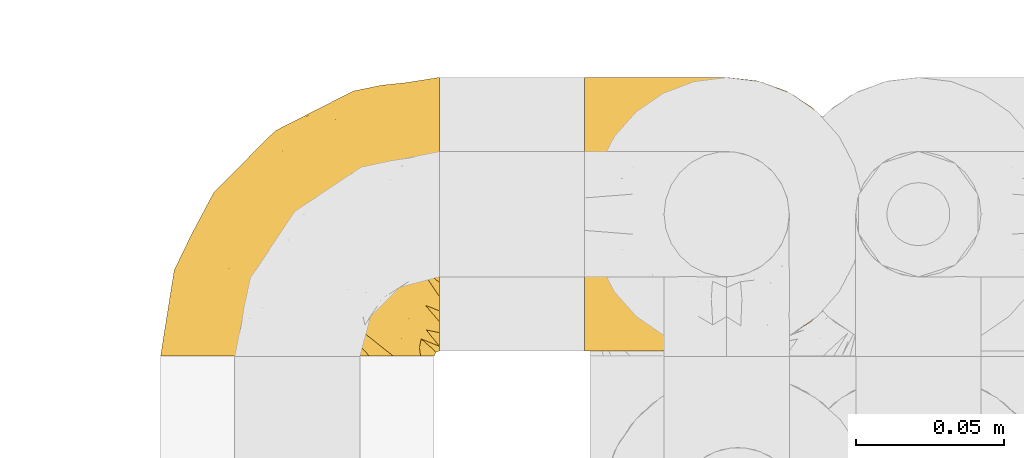
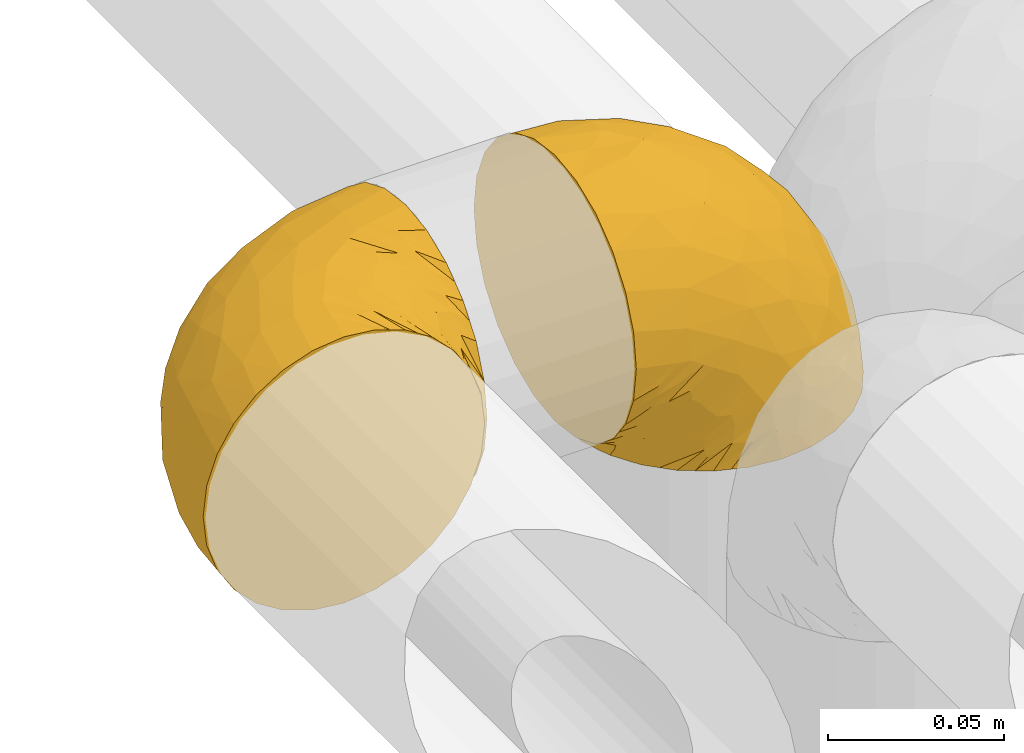
# One storey, part 239 of 827: 2 coverings.
"""IFC2X3 building model written with IfcOpenShell, lengths in millimetres."""

from ifc_helpers import new_model, entity, si_unit, converted_unit, derived_unit, direction, frame, origin, place, context, subcontext, project, spatial, faceted_brep, element, save


model = new_model("IFC2X3")

# Units and contexts
model_context = context("Model", 3, precision=0.01, world=origin(), true_north=direction((6.12303176911189e-17, 1.0)))
body_context = subcontext(model_context, "Body", "Model", "MODEL_VIEW")
ifc_project = project(units=[si_unit("LENGTHUNIT", "METRE", prefix="MILLI"), si_unit("AREAUNIT", "SQUARE_METRE"), si_unit("VOLUMEUNIT", "CUBIC_METRE"), converted_unit("PLANEANGLEUNIT", "DEGREE", entity("IfcRatioMeasure", 0.0174532925199433), si_unit("PLANEANGLEUNIT", "RADIAN"), dimensions=[0, 0, 0, 0, 0, 0, 0]), si_unit("MASSUNIT", "GRAM", prefix="KILO"), derived_unit("MASSDENSITYUNIT", [(si_unit("MASSUNIT", "GRAM", prefix="KILO"), 1), (si_unit("LENGTHUNIT", "METRE"), -3)]), derived_unit("MOMENTOFINERTIAUNIT", [(si_unit("LENGTHUNIT", "METRE"), 4)]), si_unit("TIMEUNIT", "SECOND"), si_unit("FREQUENCYUNIT", "HERTZ"), si_unit("THERMODYNAMICTEMPERATUREUNIT", "DEGREE_CELSIUS"), derived_unit("THERMALTRANSMITTANCEUNIT", [(si_unit("MASSUNIT", "GRAM", prefix="KILO"), 1), (si_unit("THERMODYNAMICTEMPERATUREUNIT", "KELVIN"), -1), (si_unit("TIMEUNIT", "SECOND"), -3)]), derived_unit("VOLUMETRICFLOWRATEUNIT", [(si_unit("LENGTHUNIT", "METRE"), 3), (si_unit("TIMEUNIT", "SECOND"), -1)]), derived_unit("MASSFLOWRATEUNIT", [(si_unit("MASSUNIT", "GRAM", prefix="KILO"), 1), (si_unit("TIMEUNIT", "SECOND"), -1)]), derived_unit("ROTATIONALFREQUENCYUNIT", [(si_unit("TIMEUNIT", "SECOND"), -1)]), si_unit("ELECTRICCURRENTUNIT", "AMPERE"), si_unit("ELECTRICVOLTAGEUNIT", "VOLT"), si_unit("POWERUNIT", "WATT"), si_unit("FORCEUNIT", "NEWTON", prefix="KILO"), si_unit("ILLUMINANCEUNIT", "LUX"), si_unit("LUMINOUSFLUXUNIT", "LUMEN"), si_unit("LUMINOUSINTENSITYUNIT", "CANDELA"), derived_unit("USERDEFINED", [(si_unit("MASSUNIT", "GRAM", prefix="KILO"), -1), (si_unit("LENGTHUNIT", "METRE"), -2), (si_unit("TIMEUNIT", "SECOND"), 3), (si_unit("LUMINOUSFLUXUNIT", "LUMEN"), 1)]), derived_unit("LINEARVELOCITYUNIT", [(si_unit("LENGTHUNIT", "METRE"), 1), (si_unit("TIMEUNIT", "SECOND"), -1)]), si_unit("PRESSUREUNIT", "PASCAL"), derived_unit("USERDEFINED", [(si_unit("LENGTHUNIT", "METRE"), -2), (si_unit("MASSUNIT", "GRAM", prefix="KILO"), 1), (si_unit("TIMEUNIT", "SECOND"), -2)]), derived_unit("LINEARFORCEUNIT", [(si_unit("MASSUNIT", "GRAM", prefix="KILO"), 1), (si_unit("LENGTHUNIT", "METRE"), 1), (si_unit("TIMEUNIT", "SECOND"), -2), (si_unit("LENGTHUNIT", "METRE"), -1)]), derived_unit("PLANARFORCEUNIT", [(si_unit("MASSUNIT", "GRAM", prefix="KILO"), 1), (si_unit("LENGTHUNIT", "METRE"), 1), (si_unit("TIMEUNIT", "SECOND"), -2), (si_unit("LENGTHUNIT", "METRE"), -2)])], contexts=[model_context])

# Site, building, storey
site_placement = place(None, origin())
site = spatial("IfcSite", under=ifc_project, at=site_placement, CompositionType="ELEMENT")
building_placement = place(site_placement, origin())
building = spatial("IfcBuilding", under=site, at=building_placement, CompositionType="ELEMENT")
storey_placement = place(building_placement, frame((0.0, 0.0, 28200.0)))
storey = spatial("IfcBuildingStorey", under=building, at=storey_placement, Name="08", CompositionType="ELEMENT", Elevation=28200.0)

# Coverings
covering_1_placement = place(storey_placement, frame((30473.73, 14966.61, 3352.2)))
element("IfcCovering", 1, at=covering_1_placement, inside=storey, Name=":ADSK_", ObjectType=":ADSK_", PredefinedType="INSULATION", context=body_context, shape_type="Brep", body=[
    faceted_brep([(18.98, 1.6, 83.91), (11.67, 1.6, 76.59), (6.17, 1.6, 67.83), (2.75, 1.6, 58.07), (1.6, 1.6, 47.8), (2.75, 1.6, 37.51), (6.17, 1.6, 27.74), (11.68, 1.6, 18.98), (19.0, 1.6, 11.67), (27.76, 1.6, 6.17), (37.52, 1.6, 2.75), (47.8, 1.6, 1.6), (51.94, 1.6, 2.06), (55.01, 1.6, 2.41), (58.08, 1.6, 2.75), (62.96, 1.6, 4.46), (67.85, 1.6, 6.17), (72.23, 1.6, 8.93), (76.61, 1.6, 11.68), (80.26, 1.6, 15.34), (83.92, 1.6, 19.0), (89.42, 1.6, 27.76), (91.13, 1.6, 32.64), (92.84, 1.6, 37.52), (94.0, 1.6, 47.8), (92.84, 1.6, 58.08), (91.13, 1.6, 62.96), (89.42, 1.6, 67.85), (83.91, 1.6, 76.61), (80.25, 1.6, 80.26), (76.59, 1.6, 83.92), (72.21, 1.6, 86.67), (67.83, 1.6, 89.42), (62.95, 1.6, 91.13), (58.07, 1.6, 92.84), (55.0, 1.6, 93.18), (51.94, 1.6, 93.53), (47.8, 1.6, 94.0), (37.51, 1.6, 92.84), (27.74, 1.6, 89.42), (95.8, 3.4, 47.8), (95.8, 4.97, 35.84), (95.8, 9.58, 24.7), (95.8, 13.26, 19.91), (95.8, 16.93, 15.13), (95.8, 21.71, 11.46), (95.8, 26.5, 7.78), (95.8, 32.07, 5.48), (95.8, 37.64, 3.17), (95.8, 41.25, 2.69), (95.8, 43.34, 2.42), (95.8, 45.42, 2.14), (95.8, 49.6, 1.6), (95.8, 61.55, 3.17), (95.8, 72.7, 7.78), (95.8, 82.26, 15.13), (95.8, 89.61, 24.7), (95.8, 94.22, 35.84), (95.8, 95.8, 47.8), (95.8, 94.22, 59.75), (95.8, 89.61, 70.9), (95.8, 82.26, 80.46), (95.8, 72.7, 87.81), (95.8, 61.55, 92.42), (95.8, 49.6, 94.0), (95.8, 45.42, 93.45), (95.8, 41.25, 92.9), (95.8, 37.64, 92.42), (95.8, 32.07, 90.11), (95.8, 26.5, 87.81), (95.8, 21.71, 84.13), (95.8, 16.93, 80.46), (95.8, 13.26, 75.68), (95.8, 9.58, 70.9), (95.8, 4.97, 59.75), (60.58, 81.55, 71.98), (74.11, 90.4, 63.6), (51.59, 83.0, 59.72), (66.69, 91.18, 47.8), (76.19, 93.13, 55.16), (84.43, 94.0, 47.8), (31.2, 66.19, 63.76), (42.88, 70.92, 72.22), (79.41, 85.95, 74.18), (60.7, 49.74, 92.52), (61.85, 35.54, 94.0), (65.75, 38.14, 94.0), (69.64, 40.74, 94.0), (73.53, 43.34, 94.0), (77.43, 45.94, 94.0), (74.59, 77.59, 82.14), (54.72, 71.17, 80.34), (64.18, 65.81, 87.52), (37.94, 59.03, 79.59), (25.89, 45.85, 78.25), (34.73, 45.79, 85.01), (42.89, 41.42, 90.25), (49.83, 34.51, 93.2), (48.58, 56.04, 87.23), (22.41, 15.15, 85.55), (78.69, 56.51, 93.0), (81.64, 68.39, 89.31), (6.22, 23.33, 61.31), (12.11, 42.86, 56.86), (14.81, 39.42, 68.34), (21.61, 53.58, 65.71), (22.41, 59.17, 56.99), (30.12, 59.06, 72.15), (10.01, 22.63, 70.34), (15.36, 20.55, 78.36), (3.39, 12.96, 47.8), (19.59, 56.96, 47.8), (30.01, 67.38, 47.8), (41.19, 18.72, 93.06), (48.54, 5.33, 94.0), (49.28, 9.07, 94.0), (49.82, 11.79, 94.0), (50.37, 14.51, 94.0), (50.91, 17.24, 94.0), (51.45, 19.96, 94.0), (31.61, 21.03, 89.88), (80.15, 46.48, 94.0), (82.88, 47.03, 94.0), (85.6, 47.57, 94.0), (88.32, 48.11, 94.0), (90.19, 48.48, 94.0), (92.06, 48.85, 94.0), (6.21, 30.7, 47.8), (54.05, 23.86, 94.0), (56.65, 27.75, 94.0), (59.25, 31.64, 94.0), (24.66, 31.26, 83.7), (40.43, 77.8, 47.8), (35.17, 72.75, 55.9), (12.9, 43.83, 47.8), (53.56, 84.49, 47.8), (85.34, 14.58, 81.75), (78.44, 16.17, 86.43), (84.37, 10.82, 79.8), (89.05, 4.64, 69.84), (82.76, 7.71, 79.5), (86.31, 25.13, 88.08), (83.73, 32.66, 91.6), (77.31, 34.94, 92.93), (87.78, 36.76, 92.43), (87.91, 40.48, 93.24), (81.29, 39.25, 93.36), (93.97, 3.69, 57.25), (70.76, 13.99, 89.41), (63.67, 21.85, 92.89), (62.62, 17.93, 92.66), (90.64, 15.11, 79.58), (84.08, 21.14, 86.51), (76.28, 12.7, 86.29), (77.45, 7.21, 83.91), (91.35, 10.45, 73.94), (88.72, 32.27, 90.94), (71.28, 25.68, 91.94), (68.09, 22.18, 91.98), (91.07, 18.79, 82.79), (57.47, 10.12, 93.16), (70.34, 9.47, 88.76), (62.99, 11.29, 91.89), (94.52, 2.87, 47.8), (76.47, 31.16, 92.22), (69.96, 6.31, 88.56), (89.86, 25.62, 87.72), (78.94, 21.18, 88.33), (73.51, 28.81, 92.18), (89.62, 7.45, 71.78), (84.09, 21.14, 9.09), (86.3, 25.13, 7.51), (91.06, 18.79, 12.8), (88.32, 48.11, 1.6), (92.06, 48.85, 1.6), (82.88, 47.03, 1.6), (85.6, 47.57, 1.6), (93.97, 3.69, 38.35), (89.63, 7.44, 23.84), (50.37, 14.51, 1.6), (49.82, 11.79, 1.6), (48.54, 5.33, 1.6), (49.28, 9.07, 1.6), (82.77, 7.71, 16.1), (70.36, 9.47, 6.84), (77.31, 34.94, 2.66), (76.47, 31.16, 3.37), (69.64, 40.74, 1.6), (65.75, 38.14, 1.6), (87.78, 36.76, 3.16), (87.91, 40.48, 2.35), (89.06, 4.63, 25.77), (90.65, 15.11, 16.02), (85.35, 14.58, 13.85), (73.53, 43.34, 1.6), (77.43, 45.94, 1.6), (81.29, 39.25, 2.23), (77.46, 7.21, 11.69), (76.29, 12.69, 9.31), (57.47, 10.14, 2.43), (63.71, 21.81, 2.71), (68.11, 22.19, 3.61), (70.77, 14.0, 6.18), (71.31, 25.69, 3.66), (78.46, 16.17, 9.17), (69.52, 6.66, 6.77), (62.64, 17.92, 2.93), (91.35, 10.45, 21.66), (59.25, 31.64, 1.6), (84.6, 10.64, 16.09), (62.98, 11.31, 3.7), (51.45, 19.96, 1.6), (54.05, 23.86, 1.6), (56.65, 27.75, 1.6), (83.73, 32.66, 3.99), (80.15, 46.48, 1.6), (88.72, 32.27, 4.65), (61.85, 35.54, 1.6), (73.56, 28.77, 3.43), (78.96, 21.17, 7.27), (91.36, 23.36, 9.46), (50.91, 17.24, 1.6), (62.87, 47.58, 2.4), (76.19, 93.13, 40.43), (73.57, 77.44, 13.57), (56.07, 66.78, 11.3), (49.77, 71.68, 18.65), (44.73, 74.96, 27.26), (60.58, 81.55, 23.61), (47.64, 36.7, 3.07), (78.32, 56.9, 2.69), (51.59, 83.0, 35.87), (74.11, 90.4, 31.99), (76.04, 67.83, 6.71), (79.41, 85.95, 21.41), (14.82, 39.41, 27.24), (6.22, 23.33, 34.26), (12.12, 42.87, 38.73), (23.51, 53.92, 26.97), (31.2, 66.19, 31.83), (34.96, 64.12, 23.4), (33.86, 33.13, 6.91), (38.94, 23.1, 3.4), (30.23, 16.98, 5.84), (35.17, 72.75, 39.69), (15.85, 23.77, 17.6), (22.59, 18.41, 10.38), (21.56, 43.7, 20.6), (55.94, 54.53, 5.36), (20.67, 55.72, 35.73), (9.19, 17.73, 24.84), (25.79, 38.98, 13.87), (41.16, 50.28, 9.06), (37.95, 59.02, 15.99)], [[[0, 1, 2, 3, 4, 5, 6, 7, 8, 9, 10, 11, 12, 13, 14, 15, 16, 17, 18, 19, 20, 21, 22, 23, 24, 25, 26, 27, 28, 29, 30, 31, 32, 33, 34, 35, 36, 37, 38, 39]], [[40, 41, 42, 43, 44, 45, 46, 47, 48, 49, 50, 51, 52, 53, 54, 55, 56, 57, 58, 59, 60, 61, 62, 63, 64, 65, 66, 67, 68, 69, 70, 71, 72, 73, 74]], [[75, 76, 77]], [[78, 79, 80]], [[77, 81, 82]], [[76, 75, 83]], [[84, 85, 86, 87, 88, 89]], [[90, 91, 92]], [[76, 60, 59]], [[93, 94, 95]], [[90, 62, 61]], [[83, 61, 60]], [[96, 97, 84]], [[98, 93, 95]], [[0, 39, 99]], [[100, 84, 89]], [[62, 101, 63]], [[2, 102, 3]], [[92, 84, 100]], [[103, 102, 104]], [[103, 105, 106]], [[93, 107, 94]], [[1, 108, 2]], [[92, 101, 90]], [[108, 1, 109]], [[102, 110, 3]], [[93, 82, 107]], [[102, 108, 104]], [[111, 106, 112]], [[109, 0, 99]], [[113, 37, 114, 115, 116, 117, 118, 119]], [[120, 38, 113]], [[100, 89, 121, 122, 123, 124, 125, 126, 64]], [[127, 102, 103]], [[97, 119, 128, 129, 130, 85]], [[99, 120, 131]], [[132, 133, 77]], [[59, 80, 79]], [[1, 0, 109]], [[98, 84, 92]], [[94, 109, 131]], [[120, 39, 38]], [[93, 91, 82]], [[104, 94, 105]], [[97, 113, 119]], [[95, 120, 96]], [[83, 90, 61]], [[91, 93, 98]], [[64, 63, 100]], [[100, 63, 101]], [[77, 76, 79]], [[133, 106, 81]], [[84, 97, 85]], [[113, 96, 120]], [[113, 97, 96]], [[37, 113, 38]], [[110, 102, 127]], [[110, 4, 3]], [[103, 111, 134, 127]], [[90, 75, 91]], [[82, 81, 107]], [[91, 75, 82]], [[77, 82, 75]], [[76, 83, 60]], [[90, 83, 75]], [[105, 107, 81]], [[94, 131, 95]], [[105, 94, 107]], [[109, 94, 104]], [[120, 95, 131]], [[98, 95, 96]], [[84, 98, 96]], [[98, 92, 91]], [[106, 105, 81]], [[103, 104, 105]], [[112, 106, 133]], [[103, 106, 111]], [[112, 133, 132]], [[81, 77, 133]], [[77, 78, 135, 132]], [[120, 99, 39]], [[109, 99, 131]], [[59, 58, 80]], [[59, 79, 76]], [[90, 101, 62]], [[100, 101, 92]], [[2, 108, 102]], [[109, 104, 108]], [[78, 77, 79]], [[136, 137, 138]], [[27, 139, 140]], [[141, 142, 143]], [[144, 145, 121]], [[146, 89, 88]], [[147, 139, 25]], [[148, 149, 150]], [[136, 151, 152]], [[147, 40, 74]], [[24, 147, 25]], [[140, 153, 154]], [[33, 116, 34]], [[73, 151, 155]], [[114, 37, 36, 35, 34, 116, 115]], [[146, 156, 144]], [[157, 85, 130]], [[158, 149, 148]], [[151, 159, 152]], [[117, 33, 160]], [[29, 154, 161]], [[155, 74, 73]], [[162, 128, 119]], [[66, 65, 64, 126, 125, 124, 123, 122, 67]], [[163, 147, 24]], [[27, 140, 28]], [[149, 129, 150]], [[139, 27, 26, 25]], [[68, 144, 69]], [[129, 128, 150]], [[164, 87, 86]], [[130, 129, 149]], [[122, 145, 67]], [[154, 153, 148]], [[162, 119, 160]], [[165, 30, 161]], [[150, 161, 148]], [[128, 162, 150]], [[30, 165, 31]], [[145, 144, 68]], [[89, 146, 144]], [[87, 164, 143]], [[166, 156, 142]], [[88, 87, 143]], [[162, 161, 150]], [[161, 30, 29]], [[154, 29, 28]], [[140, 154, 28]], [[161, 154, 148]], [[140, 137, 153]], [[158, 148, 153]], [[157, 130, 158]], [[153, 137, 158]], [[158, 137, 157]], [[167, 137, 136]], [[168, 85, 157]], [[152, 168, 167]], [[167, 168, 157]], [[164, 152, 141]], [[151, 73, 72]], [[159, 72, 71]], [[88, 142, 146]], [[144, 156, 69]], [[146, 142, 156]], [[70, 166, 71]], [[142, 141, 166]], [[70, 69, 156]], [[141, 159, 71]], [[167, 136, 152]], [[138, 137, 140]], [[155, 136, 169]], [[136, 155, 151]], [[74, 155, 169]], [[152, 159, 141]], [[151, 72, 159]], [[168, 152, 164]], [[137, 167, 157]], [[164, 86, 168]], [[85, 168, 86]], [[116, 33, 117]], [[130, 149, 158]], [[67, 145, 68]], [[121, 89, 144]], [[145, 122, 121]], [[40, 147, 163]], [[169, 147, 74]], [[160, 33, 32]], [[162, 160, 32]], [[160, 119, 118, 117]], [[139, 147, 169]], [[139, 169, 138]], [[162, 32, 31]], [[141, 143, 164]], [[88, 143, 142]], [[71, 166, 141]], [[156, 166, 70]], [[139, 138, 140]], [[169, 136, 138]], [[161, 162, 165]], [[162, 31, 165]], [[170, 171, 172]], [[173, 174, 52, 51, 50, 49, 48, 175, 176]], [[177, 178, 41]], [[179, 15, 180]], [[12, 11, 181, 182, 180, 14, 13]], [[183, 21, 20]], [[19, 18, 184]], [[185, 186, 187]], [[186, 188, 187]], [[43, 172, 44]], [[189, 190, 47]], [[23, 22, 21, 191]], [[170, 192, 193]], [[40, 163, 177]], [[194, 195, 196]], [[24, 23, 177]], [[197, 198, 183]], [[199, 15, 179]], [[178, 177, 191]], [[47, 46, 189]], [[200, 201, 202]], [[201, 203, 204]], [[205, 206, 184]], [[207, 41, 178]], [[16, 15, 199]], [[14, 180, 15]], [[202, 201, 198]], [[208, 201, 200]], [[163, 24, 177]], [[48, 47, 190]], [[196, 195, 189]], [[197, 184, 202]], [[204, 193, 209]], [[210, 211, 212]], [[206, 212, 213]], [[205, 17, 210]], [[184, 206, 202]], [[210, 212, 206]], [[185, 194, 214]], [[189, 215, 190]], [[216, 45, 214]], [[186, 171, 170]], [[189, 216, 196]], [[197, 20, 19]], [[194, 185, 187]], [[197, 183, 20]], [[184, 197, 19]], [[197, 202, 198]], [[206, 200, 202]], [[204, 183, 198]], [[201, 208, 203]], [[203, 208, 217]], [[204, 198, 201]], [[217, 188, 218]], [[193, 219, 170]], [[171, 186, 185]], [[170, 218, 186]], [[170, 219, 218]], [[42, 207, 192]], [[171, 220, 172]], [[216, 189, 46]], [[214, 194, 196]], [[44, 220, 45]], [[214, 196, 216]], [[216, 46, 45]], [[214, 45, 220]], [[192, 43, 42]], [[204, 203, 219]], [[207, 193, 192]], [[209, 193, 178]], [[41, 207, 42]], [[193, 207, 178]], [[43, 192, 172]], [[170, 172, 192]], [[204, 219, 193]], [[219, 203, 218]], [[217, 218, 203]], [[188, 186, 218]], [[206, 213, 200]], [[208, 200, 213]], [[199, 210, 16]], [[215, 189, 195]], [[215, 175, 190]], [[175, 48, 190]], [[199, 179, 221, 211]], [[210, 199, 211]], [[23, 191, 177]], [[40, 177, 41]], [[191, 183, 209]], [[21, 183, 191]], [[205, 18, 17]], [[17, 16, 210]], [[171, 185, 214]], [[172, 220, 44]], [[214, 220, 171]], [[191, 209, 178]], [[204, 209, 183]], [[206, 205, 210]], [[18, 205, 184]], [[222, 195, 194, 187, 188, 217]], [[57, 223, 80]], [[224, 225, 226]], [[226, 227, 228]], [[229, 217, 208, 213, 212, 211]], [[230, 52, 174, 173, 176, 175, 215, 195]], [[231, 232, 228]], [[231, 78, 223]], [[223, 57, 232]], [[224, 233, 225]], [[233, 54, 53]], [[234, 232, 56]], [[56, 55, 234]], [[234, 224, 228]], [[235, 236, 237]], [[224, 55, 54]], [[238, 239, 240]], [[52, 230, 53]], [[241, 242, 243]], [[231, 227, 244]], [[11, 10, 242]], [[236, 6, 5]], [[7, 245, 8]], [[8, 246, 9]], [[238, 247, 235]], [[222, 229, 248]], [[242, 211, 221, 179, 180, 182, 181, 11]], [[233, 53, 230]], [[111, 112, 249]], [[250, 6, 236]], [[246, 251, 241]], [[6, 250, 7]], [[127, 236, 110]], [[248, 229, 252]], [[246, 8, 245]], [[235, 245, 250]], [[236, 5, 110]], [[235, 249, 238]], [[237, 236, 127]], [[243, 9, 246]], [[252, 229, 241]], [[56, 232, 57]], [[222, 230, 195]], [[225, 248, 252]], [[248, 233, 230]], [[54, 233, 224]], [[231, 228, 227]], [[244, 132, 231]], [[248, 225, 233]], [[226, 225, 253]], [[235, 250, 236]], [[245, 7, 250]], [[251, 246, 245]], [[243, 246, 241]], [[247, 245, 235]], [[252, 251, 253]], [[229, 222, 217]], [[230, 222, 248]], [[5, 4, 110]], [[237, 127, 134, 111]], [[238, 249, 239]], [[224, 234, 55]], [[232, 234, 228]], [[242, 241, 229]], [[10, 9, 243]], [[211, 242, 229]], [[10, 243, 242]], [[80, 223, 78]], [[80, 58, 57]], [[231, 223, 232]], [[227, 240, 239]], [[224, 226, 228]], [[240, 226, 253]], [[227, 239, 244]], [[226, 240, 227]], [[251, 247, 253]], [[240, 253, 247]], [[249, 235, 237]], [[237, 111, 249]], [[244, 239, 249]], [[112, 244, 249]], [[135, 78, 231, 132]], [[112, 132, 244]], [[247, 238, 240]], [[245, 247, 251]], [[251, 252, 241]], [[225, 252, 253]]]),
])
covering_2_placement = place(storey_placement, frame((30616.93, 14968.41, 3350.4)))
element("IfcCovering", 2, at=covering_2_placement, inside=storey, Name=":ADSK_", ObjectType=":ADSK_", PredefinedType="INSULATION", context=body_context, shape_type="Brep", body=[
    faceted_brep([(78.41, 83.91, 1.6), (85.72, 76.59, 1.6), (91.22, 67.83, 1.6), (94.64, 58.07, 1.6), (95.8, 47.8, 1.6), (94.64, 37.51, 1.6), (91.22, 27.74, 1.6), (85.71, 18.98, 1.6), (78.39, 11.67, 1.6), (69.63, 6.17, 1.6), (59.87, 2.75, 1.6), (49.6, 1.6, 1.6), (45.45, 2.06, 1.6), (42.38, 2.41, 1.6), (39.31, 2.75, 1.6), (34.43, 4.46, 1.6), (29.54, 6.17, 1.6), (25.16, 8.93, 1.6), (20.78, 11.68, 1.6), (17.13, 15.34, 1.6), (13.47, 19.0, 1.6), (7.97, 27.76, 1.6), (6.26, 32.64, 1.6), (4.55, 37.52, 1.6), (3.4, 47.8, 1.6), (4.55, 58.08, 1.6), (6.26, 62.96, 1.6), (7.97, 67.85, 1.6), (13.48, 76.61, 1.6), (17.14, 80.26, 1.6), (20.8, 83.92, 1.6), (25.18, 86.67, 1.6), (29.56, 89.42, 1.6), (34.44, 91.13, 1.6), (39.32, 92.84, 1.6), (42.39, 93.18, 1.6), (45.45, 93.53, 1.6), (49.6, 94.0, 1.6), (59.88, 92.84, 1.6), (69.65, 89.42, 1.6), (1.6, 47.8, 3.4), (1.6, 35.84, 4.97), (1.6, 24.7, 9.58), (1.6, 19.91, 13.26), (1.6, 15.13, 16.93), (1.6, 11.46, 21.71), (1.6, 7.78, 26.5), (1.6, 5.48, 32.07), (1.6, 3.17, 37.64), (1.6, 2.69, 41.25), (1.6, 2.42, 43.34), (1.6, 2.14, 45.42), (1.6, 1.6, 49.6), (1.6, 3.17, 61.55), (1.6, 7.78, 72.7), (1.6, 15.13, 82.26), (1.6, 24.7, 89.61), (1.6, 35.84, 94.22), (1.6, 47.8, 95.8), (1.6, 59.75, 94.22), (1.6, 70.9, 89.61), (1.6, 80.46, 82.26), (1.6, 87.81, 72.7), (1.6, 92.42, 61.55), (1.6, 94.0, 49.6), (1.6, 93.45, 45.42), (1.6, 92.9, 41.25), (1.6, 92.42, 37.64), (1.6, 90.11, 32.07), (1.6, 87.81, 26.5), (1.6, 84.13, 21.71), (1.6, 80.46, 16.93), (1.6, 75.68, 13.26), (1.6, 70.9, 9.58), (1.6, 59.75, 4.97), (36.81, 71.98, 81.55), (23.28, 63.6, 90.4), (45.8, 59.72, 83.0), (30.7, 47.8, 91.18), (21.2, 55.16, 93.13), (12.96, 47.8, 94.0), (66.19, 63.76, 66.19), (54.51, 72.22, 70.92), (17.98, 74.18, 85.95), (36.69, 92.52, 49.74), (35.54, 94.0, 35.54), (31.64, 94.0, 38.14), (27.75, 94.0, 40.74), (23.86, 94.0, 43.34), (19.96, 94.0, 45.94), (22.8, 82.14, 77.59), (42.67, 80.34, 71.17), (33.21, 87.52, 65.81), (59.45, 79.59, 59.03), (71.5, 78.25, 45.85), (62.66, 85.01, 45.79), (54.5, 90.25, 41.42), (47.57, 93.2, 34.51), (48.81, 87.23, 56.04), (74.98, 85.55, 15.15), (18.7, 93.0, 56.51), (15.75, 89.31, 68.39), (91.17, 61.31, 23.33), (85.28, 56.86, 42.86), (82.58, 68.34, 39.42), (75.78, 65.71, 53.58), (74.98, 56.99, 59.17), (67.27, 72.15, 59.06), (87.38, 70.34, 22.63), (82.04, 78.36, 20.55), (94.0, 47.8, 12.96), (77.8, 47.8, 56.96), (67.38, 47.8, 67.38), (56.2, 93.06, 18.72), (48.85, 94.0, 5.33), (48.11, 94.0, 9.07), (47.57, 94.0, 11.79), (47.03, 94.0, 14.51), (46.48, 94.0, 17.24), (45.94, 94.0, 19.96), (65.78, 89.88, 21.03), (17.24, 94.0, 46.48), (14.51, 94.0, 47.03), (11.79, 94.0, 47.57), (9.07, 94.0, 48.11), (7.2, 94.0, 48.48), (5.33, 94.0, 48.85), (91.18, 47.8, 30.7), (43.34, 94.0, 23.86), (40.74, 94.0, 27.75), (38.14, 94.0, 31.64), (72.73, 83.7, 31.26), (56.96, 47.8, 77.8), (62.23, 55.9, 72.75), (84.49, 47.8, 43.83), (43.83, 47.8, 84.49), (12.05, 81.75, 14.58), (18.95, 86.43, 16.17), (13.02, 79.8, 10.82), (8.34, 69.84, 4.64), (14.63, 79.5, 7.71), (11.09, 88.08, 25.13), (13.66, 91.6, 32.66), (20.08, 92.93, 34.94), (9.61, 92.43, 36.76), (9.48, 93.24, 40.48), (16.1, 93.36, 39.25), (3.42, 57.25, 3.69), (26.63, 89.41, 13.99), (33.72, 92.89, 21.85), (34.77, 92.66, 17.93), (6.75, 79.58, 15.11), (13.31, 86.51, 21.14), (21.11, 86.29, 12.7), (19.94, 83.91, 7.21), (8.67, 90.94, 32.27), (26.11, 91.94, 25.68), (29.3, 91.98, 22.18), (6.32, 82.79, 18.79), (39.92, 93.16, 10.12), (27.05, 88.76, 9.47), (6.04, 73.94, 10.45), (34.4, 91.89, 11.29), (2.87, 47.8, 2.87), (20.92, 92.22, 31.16), (27.43, 88.56, 6.31), (7.54, 87.72, 25.62), (18.45, 88.33, 21.18), (23.88, 92.18, 28.81), (7.77, 71.78, 7.45), (13.3, 9.09, 21.14), (11.09, 7.51, 25.13), (6.33, 12.8, 18.79), (9.07, 1.6, 48.11), (5.33, 1.6, 48.85), (14.51, 1.6, 47.03), (11.79, 1.6, 47.57), (3.42, 38.35, 3.69), (7.76, 23.84, 7.44), (47.03, 1.6, 14.51), (47.57, 1.6, 11.79), (48.85, 1.6, 5.33), (48.11, 1.6, 9.07), (14.62, 16.1, 7.71), (27.03, 6.84, 9.47), (20.08, 2.66, 34.94), (20.92, 3.37, 31.16), (27.75, 1.6, 40.74), (31.64, 1.6, 38.14), (9.61, 3.16, 36.76), (9.48, 2.35, 40.48), (8.33, 25.77, 4.63), (6.74, 16.02, 15.11), (12.04, 13.85, 14.58), (23.86, 1.6, 43.34), (19.96, 1.6, 45.94), (16.1, 2.23, 39.25), (19.93, 11.69, 7.21), (21.1, 9.31, 12.69), (39.92, 2.43, 10.14), (33.68, 2.71, 21.81), (29.28, 3.61, 22.19), (26.62, 6.18, 14.0), (26.08, 3.66, 25.69), (18.93, 9.17, 16.17), (27.87, 6.77, 6.66), (34.75, 2.93, 17.92), (6.04, 21.66, 10.45), (38.14, 1.6, 31.64), (12.79, 16.09, 10.64), (34.41, 3.7, 11.31), (45.94, 1.6, 19.96), (43.34, 1.6, 23.86), (40.74, 1.6, 27.75), (13.66, 3.99, 32.66), (17.24, 1.6, 46.48), (8.67, 4.65, 32.27), (35.54, 1.6, 35.54), (23.83, 3.43, 28.77), (18.43, 7.27, 21.17), (6.03, 9.46, 23.36), (46.48, 1.6, 17.24), (34.52, 2.4, 47.58), (21.2, 40.43, 93.13), (23.82, 13.57, 77.44), (41.32, 11.3, 66.78), (47.62, 18.65, 71.68), (52.66, 27.26, 74.96), (36.81, 23.61, 81.55), (49.75, 3.07, 36.7), (19.07, 2.69, 56.9), (45.8, 35.87, 83.0), (23.28, 31.99, 90.4), (21.35, 6.71, 67.83), (17.98, 21.41, 85.95), (82.57, 27.24, 39.41), (91.17, 34.26, 23.33), (85.27, 38.73, 42.87), (73.89, 26.97, 53.92), (66.19, 31.83, 66.19), (62.43, 23.4, 64.12), (63.53, 6.91, 33.13), (58.45, 3.4, 23.1), (67.16, 5.84, 16.98), (62.22, 39.69, 72.75), (81.54, 17.6, 23.77), (74.8, 10.38, 18.41), (75.83, 20.6, 43.7), (41.45, 5.36, 54.53), (76.72, 35.73, 55.72), (88.2, 24.84, 17.73), (71.6, 13.87, 38.98), (56.23, 9.06, 50.28), (59.44, 15.99, 59.02)], [[[0, 1, 2, 3, 4, 5, 6, 7, 8, 9, 10, 11, 12, 13, 14, 15, 16, 17, 18, 19, 20, 21, 22, 23, 24, 25, 26, 27, 28, 29, 30, 31, 32, 33, 34, 35, 36, 37, 38, 39]], [[40, 41, 42, 43, 44, 45, 46, 47, 48, 49, 50, 51, 52, 53, 54, 55, 56, 57, 58, 59, 60, 61, 62, 63, 64, 65, 66, 67, 68, 69, 70, 71, 72, 73, 74]], [[75, 76, 77]], [[78, 79, 80]], [[77, 81, 82]], [[76, 75, 83]], [[84, 85, 86, 87, 88, 89]], [[90, 91, 92]], [[76, 60, 59]], [[93, 94, 95]], [[90, 62, 61]], [[83, 61, 60]], [[96, 97, 84]], [[98, 93, 95]], [[0, 39, 99]], [[100, 84, 89]], [[62, 101, 63]], [[2, 102, 3]], [[92, 84, 100]], [[103, 102, 104]], [[103, 105, 106]], [[93, 107, 94]], [[1, 108, 2]], [[92, 101, 90]], [[108, 1, 109]], [[102, 110, 3]], [[93, 82, 107]], [[102, 108, 104]], [[111, 106, 112]], [[109, 0, 99]], [[113, 37, 114, 115, 116, 117, 118, 119]], [[120, 38, 113]], [[100, 89, 121, 122, 123, 124, 125, 126, 64]], [[127, 102, 103]], [[97, 119, 128, 129, 130, 85]], [[99, 120, 131]], [[132, 133, 77]], [[59, 80, 79]], [[1, 0, 109]], [[98, 84, 92]], [[94, 109, 131]], [[120, 39, 38]], [[93, 91, 82]], [[104, 94, 105]], [[97, 113, 119]], [[95, 120, 96]], [[83, 90, 61]], [[91, 93, 98]], [[64, 63, 100]], [[100, 63, 101]], [[77, 76, 79]], [[133, 106, 81]], [[84, 97, 85]], [[113, 96, 120]], [[113, 97, 96]], [[37, 113, 38]], [[110, 102, 127]], [[110, 4, 3]], [[103, 111, 134, 127]], [[90, 75, 91]], [[82, 81, 107]], [[91, 75, 82]], [[77, 82, 75]], [[76, 83, 60]], [[90, 83, 75]], [[105, 107, 81]], [[94, 131, 95]], [[105, 94, 107]], [[109, 94, 104]], [[120, 95, 131]], [[98, 95, 96]], [[84, 98, 96]], [[98, 92, 91]], [[106, 105, 81]], [[103, 104, 105]], [[112, 106, 133]], [[103, 106, 111]], [[112, 133, 132]], [[81, 77, 133]], [[77, 78, 135, 132]], [[120, 99, 39]], [[109, 99, 131]], [[59, 58, 80]], [[59, 79, 76]], [[90, 101, 62]], [[100, 101, 92]], [[2, 108, 102]], [[109, 104, 108]], [[78, 77, 79]], [[136, 137, 138]], [[27, 139, 140]], [[141, 142, 143]], [[144, 145, 121]], [[146, 89, 88]], [[147, 139, 25]], [[148, 149, 150]], [[136, 151, 152]], [[147, 40, 74]], [[24, 147, 25]], [[140, 153, 154]], [[33, 116, 34]], [[73, 72, 151]], [[114, 37, 36, 35, 34, 116, 115]], [[146, 155, 144]], [[156, 85, 130]], [[157, 149, 148]], [[151, 158, 152]], [[117, 33, 159]], [[29, 154, 160]], [[161, 74, 73]], [[162, 128, 119]], [[66, 65, 64, 126, 125, 124, 123, 122, 67]], [[163, 147, 24]], [[27, 140, 28]], [[149, 129, 150]], [[139, 27, 26, 25]], [[68, 144, 69]], [[129, 128, 150]], [[164, 87, 86]], [[130, 129, 149]], [[122, 145, 67]], [[154, 153, 148]], [[162, 119, 159]], [[165, 30, 160]], [[150, 160, 148]], [[128, 162, 150]], [[30, 165, 31]], [[145, 144, 68]], [[89, 146, 144]], [[87, 164, 143]], [[166, 155, 142]], [[88, 87, 143]], [[162, 160, 150]], [[160, 30, 29]], [[154, 29, 28]], [[140, 154, 28]], [[160, 154, 148]], [[140, 137, 153]], [[157, 148, 153]], [[156, 130, 157]], [[153, 137, 157]], [[157, 137, 156]], [[167, 137, 136]], [[168, 85, 156]], [[152, 168, 167]], [[167, 168, 156]], [[164, 152, 141]], [[71, 158, 72]], [[152, 167, 136]], [[88, 142, 146]], [[144, 155, 69]], [[146, 142, 155]], [[70, 166, 71]], [[142, 141, 166]], [[70, 69, 155]], [[141, 158, 71]], [[161, 73, 151]], [[138, 137, 140]], [[161, 136, 169]], [[136, 161, 151]], [[74, 161, 169]], [[152, 158, 141]], [[151, 72, 158]], [[168, 152, 164]], [[137, 167, 156]], [[164, 86, 168]], [[85, 168, 86]], [[116, 33, 117]], [[130, 149, 157]], [[67, 145, 68]], [[121, 89, 144]], [[145, 122, 121]], [[40, 147, 163]], [[169, 147, 74]], [[159, 33, 32]], [[162, 159, 32]], [[159, 119, 118, 117]], [[139, 147, 169]], [[139, 169, 138]], [[162, 32, 31]], [[141, 143, 164]], [[88, 143, 142]], [[71, 166, 141]], [[155, 166, 70]], [[139, 138, 140]], [[169, 136, 138]], [[160, 162, 165]], [[162, 31, 165]], [[170, 171, 172]], [[173, 174, 52, 51, 50, 49, 48, 175, 176]], [[177, 178, 41]], [[179, 15, 180]], [[12, 11, 181, 182, 180, 14, 13]], [[183, 21, 20]], [[19, 18, 184]], [[185, 186, 187]], [[186, 188, 187]], [[43, 172, 44]], [[189, 190, 47]], [[23, 22, 21, 191]], [[170, 192, 193]], [[40, 163, 177]], [[194, 195, 196]], [[24, 23, 177]], [[197, 198, 183]], [[199, 15, 179]], [[47, 46, 189]], [[200, 201, 202]], [[201, 203, 204]], [[205, 206, 184]], [[207, 41, 178]], [[16, 15, 199]], [[14, 180, 15]], [[202, 201, 198]], [[208, 201, 200]], [[163, 24, 177]], [[48, 47, 190]], [[196, 195, 189]], [[197, 184, 202]], [[204, 193, 209]], [[210, 211, 212]], [[206, 212, 213]], [[205, 17, 210]], [[184, 206, 202]], [[210, 212, 206]], [[185, 194, 214]], [[189, 215, 190]], [[216, 45, 214]], [[186, 171, 170]], [[189, 216, 196]], [[197, 20, 19]], [[194, 185, 187]], [[197, 183, 20]], [[184, 197, 19]], [[197, 202, 198]], [[206, 200, 202]], [[204, 183, 198]], [[201, 208, 203]], [[203, 208, 217]], [[204, 198, 201]], [[217, 188, 218]], [[193, 219, 170]], [[171, 186, 185]], [[170, 218, 186]], [[170, 219, 218]], [[42, 207, 192]], [[171, 220, 172]], [[216, 189, 46]], [[214, 194, 196]], [[44, 220, 45]], [[214, 196, 216]], [[216, 46, 45]], [[214, 45, 220]], [[192, 43, 42]], [[204, 203, 219]], [[207, 193, 192]], [[209, 193, 178]], [[41, 207, 42]], [[193, 207, 178]], [[43, 192, 172]], [[170, 172, 192]], [[204, 219, 193]], [[219, 203, 218]], [[217, 218, 203]], [[188, 186, 218]], [[206, 213, 200]], [[208, 200, 213]], [[199, 210, 16]], [[215, 189, 195]], [[215, 175, 190]], [[175, 48, 190]], [[199, 179, 221, 211]], [[210, 199, 211]], [[23, 191, 177]], [[40, 177, 41]], [[178, 177, 191]], [[21, 183, 191]], [[209, 191, 183]], [[205, 18, 17]], [[17, 16, 210]], [[171, 185, 214]], [[172, 220, 44]], [[214, 220, 171]], [[191, 209, 178]], [[204, 209, 183]], [[206, 205, 210]], [[18, 205, 184]], [[222, 195, 194, 187, 188, 217]], [[57, 223, 80]], [[224, 225, 226]], [[226, 227, 228]], [[229, 217, 208, 213, 212, 211]], [[230, 52, 174, 173, 176, 175, 215, 195]], [[231, 232, 228]], [[231, 78, 223]], [[223, 57, 232]], [[224, 233, 225]], [[233, 54, 53]], [[234, 232, 56]], [[56, 55, 234]], [[234, 224, 228]], [[235, 236, 237]], [[224, 55, 54]], [[238, 239, 240]], [[52, 230, 53]], [[241, 242, 243]], [[227, 244, 231]], [[11, 10, 242]], [[236, 6, 5]], [[7, 245, 8]], [[8, 246, 9]], [[238, 247, 235]], [[222, 229, 248]], [[242, 211, 221, 179, 180, 182, 181, 11]], [[233, 53, 230]], [[111, 112, 249]], [[250, 6, 236]], [[246, 251, 241]], [[6, 250, 7]], [[127, 236, 110]], [[248, 229, 252]], [[246, 8, 245]], [[235, 245, 250]], [[236, 5, 110]], [[235, 249, 238]], [[237, 236, 127]], [[243, 9, 246]], [[252, 229, 241]], [[56, 232, 57]], [[222, 230, 195]], [[225, 248, 252]], [[248, 233, 230]], [[54, 233, 224]], [[231, 228, 227]], [[244, 132, 231]], [[248, 225, 233]], [[226, 225, 253]], [[235, 250, 236]], [[245, 7, 250]], [[251, 246, 245]], [[243, 246, 241]], [[247, 245, 235]], [[252, 251, 253]], [[229, 222, 217]], [[230, 222, 248]], [[5, 4, 110]], [[237, 127, 134, 111]], [[238, 249, 239]], [[224, 234, 55]], [[232, 234, 228]], [[242, 241, 229]], [[10, 9, 243]], [[211, 242, 229]], [[10, 243, 242]], [[80, 223, 78]], [[80, 58, 57]], [[231, 223, 232]], [[227, 240, 239]], [[224, 226, 228]], [[240, 226, 253]], [[227, 239, 244]], [[226, 240, 227]], [[251, 247, 253]], [[240, 253, 247]], [[249, 235, 237]], [[237, 111, 249]], [[112, 132, 244]], [[112, 244, 249]], [[78, 231, 132, 135]], [[249, 244, 239]], [[247, 238, 240]], [[245, 247, 251]], [[251, 252, 241]], [[225, 252, 253]]]),
])

save(model, "model.ifc")
